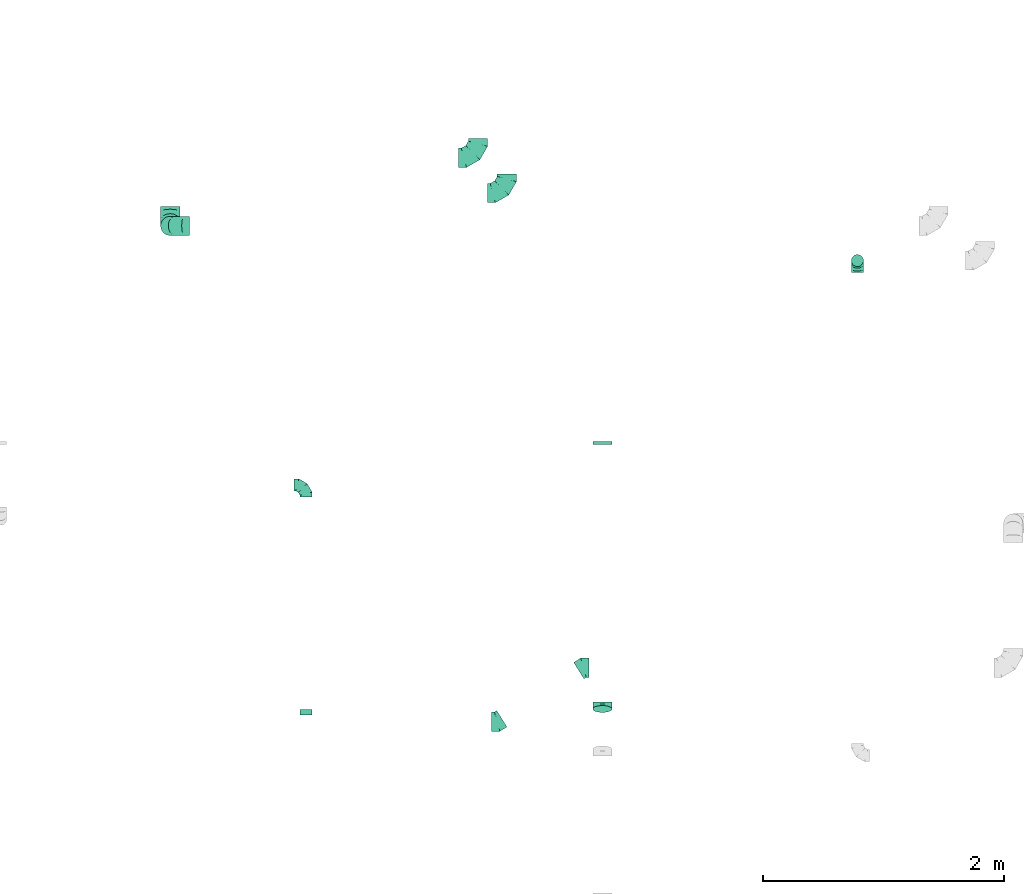
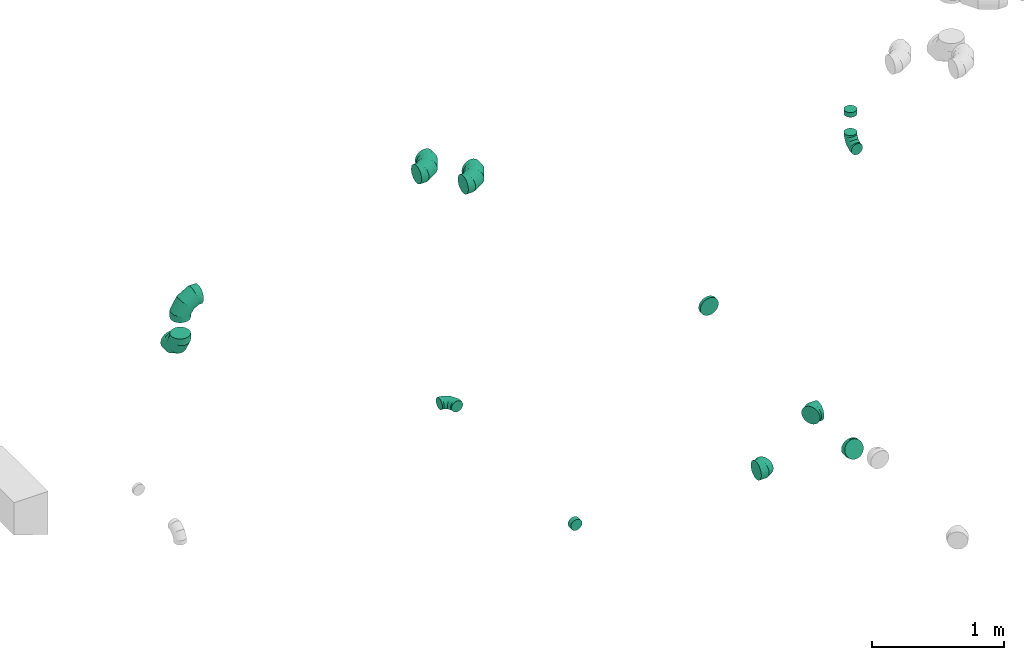
# One storey, part 5 of 32: 12 flow fittings.
"""IFC2X3 building model written with IfcOpenShell, lengths in millimetres."""

from ifc_helpers import new_model, entity, si_unit, converted_unit, derived_unit, direction, frame, origin, place, context, subcontext, project, spatial, faceted_brep, source, transform, mapped, material, type_object, type_shapes, element, save


model = new_model("IFC2X3")

# Units and contexts
model_context = context("Model", 3, precision=0.01, world=origin(), true_north=direction((6.12303176911189e-17, 1.0)))
body_context = subcontext(model_context, "Body", "Model", "MODEL_VIEW")
ifc_project = project(units=[si_unit("LENGTHUNIT", "METRE", prefix="MILLI"), si_unit("AREAUNIT", "SQUARE_METRE"), si_unit("VOLUMEUNIT", "CUBIC_METRE"), converted_unit("PLANEANGLEUNIT", "DEGREE", entity("IfcRatioMeasure", 0.0174532925199433), si_unit("PLANEANGLEUNIT", "RADIAN"), dimensions=[0, 0, 0, 0, 0, 0, 0]), si_unit("MASSUNIT", "GRAM", prefix="KILO"), derived_unit("MASSDENSITYUNIT", [(si_unit("MASSUNIT", "GRAM", prefix="KILO"), 1), (si_unit("LENGTHUNIT", "METRE"), -3)]), derived_unit("MOMENTOFINERTIAUNIT", [(si_unit("LENGTHUNIT", "METRE"), 4)]), si_unit("TIMEUNIT", "SECOND"), si_unit("FREQUENCYUNIT", "HERTZ"), si_unit("THERMODYNAMICTEMPERATUREUNIT", "DEGREE_CELSIUS"), derived_unit("THERMALTRANSMITTANCEUNIT", [(si_unit("MASSUNIT", "GRAM", prefix="KILO"), 1), (si_unit("THERMODYNAMICTEMPERATUREUNIT", "KELVIN"), -1), (si_unit("TIMEUNIT", "SECOND"), -3)]), derived_unit("VOLUMETRICFLOWRATEUNIT", [(si_unit("LENGTHUNIT", "METRE"), 3), (si_unit("TIMEUNIT", "SECOND"), -1)]), derived_unit("MASSFLOWRATEUNIT", [(si_unit("MASSUNIT", "GRAM", prefix="KILO"), 1), (si_unit("TIMEUNIT", "SECOND"), -1)]), derived_unit("ROTATIONALFREQUENCYUNIT", [(si_unit("TIMEUNIT", "SECOND"), -1)]), si_unit("ELECTRICCURRENTUNIT", "AMPERE"), si_unit("ELECTRICVOLTAGEUNIT", "VOLT"), si_unit("POWERUNIT", "WATT"), si_unit("FORCEUNIT", "NEWTON", prefix="KILO"), si_unit("ILLUMINANCEUNIT", "LUX"), si_unit("LUMINOUSFLUXUNIT", "LUMEN"), si_unit("LUMINOUSINTENSITYUNIT", "CANDELA"), derived_unit("USERDEFINED", [(si_unit("MASSUNIT", "GRAM", prefix="KILO"), -1), (si_unit("LENGTHUNIT", "METRE"), -2), (si_unit("TIMEUNIT", "SECOND"), 3), (si_unit("LUMINOUSFLUXUNIT", "LUMEN"), 1)]), derived_unit("LINEARVELOCITYUNIT", [(si_unit("LENGTHUNIT", "METRE"), 1), (si_unit("TIMEUNIT", "SECOND"), -1)]), si_unit("PRESSUREUNIT", "PASCAL"), derived_unit("USERDEFINED", [(si_unit("LENGTHUNIT", "METRE"), -2), (si_unit("MASSUNIT", "GRAM", prefix="KILO"), 1), (si_unit("TIMEUNIT", "SECOND"), -2)]), derived_unit("LINEARFORCEUNIT", [(si_unit("MASSUNIT", "GRAM", prefix="KILO"), 1), (si_unit("LENGTHUNIT", "METRE"), 1), (si_unit("TIMEUNIT", "SECOND"), -2), (si_unit("LENGTHUNIT", "METRE"), -1)]), derived_unit("PLANARFORCEUNIT", [(si_unit("MASSUNIT", "GRAM", prefix="KILO"), 1), (si_unit("LENGTHUNIT", "METRE"), 1), (si_unit("TIMEUNIT", "SECOND"), -2), (si_unit("LENGTHUNIT", "METRE"), -2)])], contexts=[model_context])

# Site, building, storey
site_placement = place(None, origin())
site = spatial("IfcSite", under=ifc_project, at=site_placement, CompositionType="ELEMENT")
building_placement = place(site_placement, origin())
building = spatial("IfcBuilding", under=site, at=building_placement, CompositionType="ELEMENT")
storey_placement = place(building_placement, frame((0.0, 0.0, 8100.0)))
storey = spatial("IfcBuildingStorey", under=building, at=storey_placement, CompositionType="ELEMENT", Elevation=8100.0)

# Flow fittings
ifc_material = material()
duct_fitting_type_1 = type_object("IfcDuctFittingType", PredefinedType="NOTDEFINED", material=ifc_material)
shared_shape_1 = source(origin(), body_context, "Body", "Brep", [
    faceted_brep([(-160.0, 0.0, -80.0), (-160.0, -20.71, -77.27), (-160.0, -40.0, -69.28), (-160.0, -56.57, -56.57), (-160.0, -69.28, -40.0), (-160.0, -77.27, -20.71), (-160.0, -80.0, 0.0), (-160.0, -77.27, 20.71), (-160.0, -69.28, 40.0), (-160.0, -56.57, 56.57), (-160.0, -40.0, 69.28), (-160.0, -20.71, 77.27), (-160.0, 0.0, 80.0), (-160.0, 20.71, 77.27), (-160.0, 40.0, 69.28), (-160.0, 56.57, 56.57), (-160.0, 69.28, 40.0), (-160.0, 77.27, 20.71), (-160.0, 80.0, 0.0), (-160.0, 77.27, -20.71), (-160.0, 69.28, -40.0), (-160.0, 56.57, -56.57), (-160.0, 40.0, -69.28), (-160.0, 20.71, -77.27), (-122.68, 20.71, 77.27), (-127.85, 40.0, 69.28), (-117.13, 0.0, 80.0), (-132.29, 56.57, 56.57), (-137.83, 77.27, 20.71), (-138.56, 80.0, 0.0), (-135.69, 69.28, 40.0), (-135.69, 69.28, -40.0), (-132.29, 56.57, -56.57), (-137.83, 77.27, -20.71), (-122.68, 20.71, -77.27), (-117.13, 0.0, -80.0), (-127.85, 40.0, -69.28), (-111.58, -20.71, -77.27), (-106.41, -40.0, -69.28), (-101.97, -56.57, -56.57), (-98.56, -69.28, -40.0), (-96.42, -77.27, -20.71), (-95.69, -80.0, 0.0), (-96.42, -77.27, 20.71), (-98.56, -69.28, 40.0), (-101.97, -56.57, 56.57), (-106.41, -40.0, 69.28), (-111.58, -20.71, 77.27), (-58.03, 58.03, 77.27), (-72.15, 72.15, 69.28), (-42.87, 42.87, 80.0), (-84.28, 84.28, 56.57), (-93.59, 93.59, 40.0), (-99.44, 99.44, 20.71), (-101.44, 101.44, 0.0), (-99.44, 99.44, -20.71), (-93.59, 93.59, -40.0), (-84.28, 84.28, -56.57), (-58.03, 58.03, -77.27), (-42.87, 42.87, -80.0), (-72.15, 72.15, -69.28), (-27.71, 27.71, -77.27), (-13.59, 13.59, -69.28), (-1.46, 1.46, -56.57), (7.85, -7.85, -40.0), (13.7, -13.7, -20.71), (15.69, -15.69, 0.0), (13.7, -13.7, 20.71), (7.85, -7.85, 40.0), (-1.46, 1.46, 56.57), (-13.59, 13.59, 69.28), (-27.71, 27.71, 77.27), (-20.71, 122.68, 77.27), (-40.0, 127.85, 69.28), (0.0, 117.13, 80.0), (-56.57, 132.29, 56.57), (-69.28, 135.69, 40.0), (-77.27, 137.83, 20.71), (-80.0, 138.56, 0.0), (-77.27, 137.83, -20.71), (-69.28, 135.69, -40.0), (-56.57, 132.29, -56.57), (-20.71, 122.68, -77.27), (0.0, 117.13, -80.0), (-40.0, 127.85, -69.28), (20.71, 111.58, -77.27), (40.0, 106.41, -69.28), (56.57, 101.97, -56.57), (69.28, 98.56, -40.0), (77.27, 96.42, -20.71), (80.0, 95.69, 0.0), (77.27, 96.42, 20.71), (69.28, 98.56, 40.0), (56.57, 101.97, 56.57), (40.0, 106.41, 69.28), (20.71, 111.58, 77.27), (-20.71, 160.0, -77.27), (-40.0, 160.0, -69.28), (-56.57, 160.0, -56.57), (-69.28, 160.0, -40.0), (-77.27, 160.0, -20.71), (-80.0, 160.0, 0.0), (-77.27, 160.0, 20.71), (-69.28, 160.0, 40.0), (-56.57, 160.0, 56.57), (-40.0, 160.0, 69.28), (-20.71, 160.0, 77.27), (0.0, 160.0, 80.0), (20.71, 160.0, 77.27), (40.0, 160.0, 69.28), (56.57, 160.0, 56.57), (69.28, 160.0, 40.0), (77.27, 160.0, 20.71), (80.0, 160.0, 0.0), (77.27, 160.0, -20.71), (69.28, 160.0, -40.0), (56.57, 160.0, -56.57), (40.0, 160.0, -69.28), (20.71, 160.0, -77.27), (0.0, 160.0, -80.0)], [[[0, 1, 2, 3, 4, 5, 6, 7, 8, 9, 10, 11, 12, 13, 14, 15, 16, 17, 18, 19, 20, 21, 22, 23]], [[24, 25, 14, 13]], [[26, 24, 13, 12]], [[14, 25, 27, 15]], [[28, 29, 18, 17]], [[30, 28, 17, 16]], [[15, 27, 30, 16]], [[20, 31, 32, 21]], [[33, 31, 20, 19]], [[18, 29, 33, 19]], [[34, 35, 0, 23]], [[36, 34, 23, 22]], [[32, 36, 22, 21]], [[1, 0, 35, 37]], [[2, 1, 37, 38]], [[3, 2, 38, 39]], [[5, 4, 40, 41]], [[6, 5, 41, 42]], [[39, 40, 4, 3]], [[6, 42, 43, 7]], [[7, 43, 44, 8]], [[8, 44, 45, 9]], [[9, 45, 46, 10]], [[10, 46, 47, 11]], [[26, 12, 11, 47]], [[48, 49, 25, 24]], [[50, 48, 24, 26]], [[27, 25, 49, 51]], [[52, 53, 28, 30]], [[51, 52, 30, 27]], [[29, 28, 53, 54]], [[55, 56, 31, 33]], [[54, 55, 33, 29]], [[32, 31, 56, 57]], [[58, 59, 35, 34]], [[60, 58, 34, 36]], [[57, 60, 36, 32]], [[37, 35, 59, 61]], [[38, 37, 61, 62]], [[39, 38, 62, 63]], [[41, 40, 64, 65]], [[42, 41, 65, 66]], [[63, 64, 40, 39]], [[43, 42, 66, 67]], [[44, 43, 67, 68]], [[68, 69, 45, 44]], [[46, 45, 69, 70]], [[47, 46, 70, 71]], [[26, 47, 71, 50]], [[72, 73, 49, 48]], [[74, 72, 48, 50]], [[51, 49, 73, 75]], [[76, 77, 53, 52]], [[75, 76, 52, 51]], [[54, 53, 77, 78]], [[79, 80, 56, 55]], [[78, 79, 55, 54]], [[57, 56, 80, 81]], [[82, 83, 59, 58]], [[84, 82, 58, 60]], [[81, 84, 60, 57]], [[61, 59, 83, 85]], [[62, 61, 85, 86]], [[63, 62, 86, 87]], [[65, 64, 88, 89]], [[66, 65, 89, 90]], [[87, 88, 64, 63]], [[67, 66, 90, 91]], [[68, 67, 91, 92]], [[92, 93, 69, 68]], [[70, 69, 93, 94]], [[71, 70, 94, 95]], [[50, 71, 95, 74]], [[96, 97, 98, 99, 100, 101, 102, 103, 104, 105, 106, 107, 108, 109, 110, 111, 112, 113, 114, 115, 116, 117, 118, 119]], [[72, 74, 107, 106]], [[73, 72, 106, 105]], [[75, 73, 105, 104]], [[77, 76, 103, 102]], [[78, 77, 102, 101]], [[75, 104, 103, 76]], [[78, 101, 100, 79]], [[79, 100, 99, 80]], [[80, 99, 98, 81]], [[84, 97, 96, 82]], [[82, 96, 119, 83]], [[84, 81, 98, 97]], [[118, 117, 86, 85]], [[119, 118, 85, 83]], [[116, 87, 86, 117]], [[88, 115, 114, 89]], [[89, 114, 113, 90]], [[115, 88, 87, 116]], [[112, 111, 92, 91]], [[113, 112, 91, 90]], [[111, 110, 93, 92]], [[95, 94, 109, 108]], [[74, 95, 108, 107]], [[110, 109, 94, 93]]]),
])
type_shapes(duct_fitting_type_1, [shared_shape_1])
for number, where in (
    (1, (13323.56, 12986.64, 3350.0)),
    (2, (13083.56, 13280.27, 3350.0)),
):
    element("IfcFlowFitting", number, at=place(storey_placement, frame(where)), inside=storey, type_object=duct_fitting_type_1, material=ifc_material, context=body_context, shape_type="MappedRepresentation", body=[
        mapped(shared_shape_1, transform((0.0, 0.0, 0.0), scale=1.0)),
    ])
for number, where, z_axis, x_axis in (
    (3, (10524.9, 12714.35, 2900.0), (-1.0, 0.0, 0.0), (0.0, -1.0, 0.0)),
    (4, (10524.9, 12714.35, 3370.0), (0.0, -1.0, 0.0), (-1.0, 0.0, 0.0)),
):
    element("IfcFlowFitting", number, at=place(storey_placement, frame(where, z_axis=z_axis, x_axis=x_axis)), inside=storey, type_object=duct_fitting_type_1, material=ifc_material, context=body_context, shape_type="MappedRepresentation", body=[
        mapped(shared_shape_1, transform((0.0, 0.0, 0.0), scale=1.0)),
    ])
duct_fitting_type_2 = type_object("IfcDuctFittingType", PredefinedType="NOTDEFINED", material=ifc_material)
shared_shape_2 = source(origin(), body_context, "Body", "Brep", [
    faceted_brep([(-100.0, 0.0, -50.0), (-100.0, -12.94, -48.3), (-100.0, -25.0, -43.3), (-100.0, -35.36, -35.36), (-100.0, -43.3, -25.0), (-100.0, -48.3, -12.94), (-100.0, -50.0, 0.0), (-100.0, -48.3, 12.94), (-100.0, -43.3, 25.0), (-100.0, -35.36, 35.36), (-100.0, -25.0, 43.3), (-100.0, -12.94, 48.3), (-100.0, 0.0, 50.0), (-100.0, 12.94, 48.3), (-100.0, 25.0, 43.3), (-100.0, 35.36, 35.36), (-100.0, 43.3, 25.0), (-100.0, 48.3, 12.94), (-100.0, 50.0, 0.0), (-100.0, 48.3, -12.94), (-100.0, 43.3, -25.0), (-100.0, 35.36, -35.36), (-100.0, 25.0, -43.3), (-100.0, 12.94, -48.3), (-76.67, 12.94, 48.3), (-79.9, 25.0, 43.3), (-73.21, 0.0, 50.0), (-82.68, 35.36, 35.36), (-86.15, 48.3, 12.94), (-86.6, 50.0, 0.0), (-84.81, 43.3, 25.0), (-84.81, 43.3, -25.0), (-82.68, 35.36, -35.36), (-86.15, 48.3, -12.94), (-76.67, 12.94, -48.3), (-73.21, 0.0, -50.0), (-79.9, 25.0, -43.3), (-69.74, -12.94, -48.3), (-66.51, -25.0, -43.3), (-63.73, -35.36, -35.36), (-61.6, -43.3, -25.0), (-60.26, -48.3, -12.94), (-59.81, -50.0, 0.0), (-60.26, -48.3, 12.94), (-61.6, -43.3, 25.0), (-63.73, -35.36, 35.36), (-66.51, -25.0, 43.3), (-69.74, -12.94, 48.3), (-36.27, 36.27, 48.3), (-45.1, 45.1, 43.3), (-26.79, 26.79, 50.0), (-52.68, 52.68, 35.36), (-58.49, 58.49, 25.0), (-62.15, 62.15, 12.94), (-63.4, 63.4, 0.0), (-62.15, 62.15, -12.94), (-58.49, 58.49, -25.0), (-52.68, 52.68, -35.36), (-36.27, 36.27, -48.3), (-26.79, 26.79, -50.0), (-45.1, 45.1, -43.3), (-17.32, 17.32, -48.3), (-8.49, 8.49, -43.3), (-0.91, 0.91, -35.36), (4.9, -4.9, -25.0), (8.56, -8.56, -12.94), (9.81, -9.81, 0.0), (8.56, -8.56, 12.94), (4.9, -4.9, 25.0), (-0.91, 0.91, 35.36), (-8.49, 8.49, 43.3), (-17.32, 17.32, 48.3), (-12.94, 76.67, 48.3), (-25.0, 79.9, 43.3), (0.0, 73.21, 50.0), (-35.36, 82.68, 35.36), (-43.3, 84.81, 25.0), (-48.3, 86.15, 12.94), (-50.0, 86.6, 0.0), (-48.3, 86.15, -12.94), (-43.3, 84.81, -25.0), (-35.36, 82.68, -35.36), (-12.94, 76.67, -48.3), (0.0, 73.21, -50.0), (-25.0, 79.9, -43.3), (12.94, 69.74, -48.3), (25.0, 66.51, -43.3), (35.36, 63.73, -35.36), (43.3, 61.6, -25.0), (48.3, 60.26, -12.94), (50.0, 59.81, 0.0), (48.3, 60.26, 12.94), (43.3, 61.6, 25.0), (35.36, 63.73, 35.36), (25.0, 66.51, 43.3), (12.94, 69.74, 48.3), (-12.94, 100.0, -48.3), (-25.0, 100.0, -43.3), (-35.36, 100.0, -35.36), (-43.3, 100.0, -25.0), (-48.3, 100.0, -12.94), (-50.0, 100.0, 0.0), (-48.3, 100.0, 12.94), (-43.3, 100.0, 25.0), (-35.36, 100.0, 35.36), (-25.0, 100.0, 43.3), (-12.94, 100.0, 48.3), (0.0, 100.0, 50.0), (12.94, 100.0, 48.3), (25.0, 100.0, 43.3), (35.36, 100.0, 35.36), (43.3, 100.0, 25.0), (48.3, 100.0, 12.94), (50.0, 100.0, 0.0), (48.3, 100.0, -12.94), (43.3, 100.0, -25.0), (35.36, 100.0, -35.36), (25.0, 100.0, -43.3), (12.94, 100.0, -48.3), (0.0, 100.0, -50.0)], [[[0, 1, 2, 3, 4, 5, 6, 7, 8, 9, 10, 11, 12, 13, 14, 15, 16, 17, 18, 19, 20, 21, 22, 23]], [[24, 25, 14, 13]], [[26, 24, 13, 12]], [[14, 25, 27, 15]], [[28, 29, 18, 17]], [[30, 28, 17, 16]], [[15, 27, 30, 16]], [[20, 31, 32, 21]], [[33, 31, 20, 19]], [[18, 29, 33, 19]], [[34, 35, 0, 23]], [[36, 34, 23, 22]], [[32, 36, 22, 21]], [[2, 1, 37, 38]], [[3, 2, 38, 39]], [[0, 35, 37, 1]], [[5, 4, 40, 41]], [[6, 5, 41, 42]], [[3, 39, 40, 4]], [[6, 42, 43, 7]], [[7, 43, 44, 8]], [[8, 44, 45, 9]], [[10, 46, 47, 11]], [[11, 47, 26, 12]], [[10, 9, 45, 46]], [[48, 49, 25, 24]], [[50, 48, 24, 26]], [[27, 25, 49, 51]], [[52, 53, 28, 30]], [[51, 52, 30, 27]], [[29, 28, 53, 54]], [[55, 56, 31, 33]], [[54, 55, 33, 29]], [[57, 32, 31, 56]], [[58, 59, 35, 34]], [[60, 58, 34, 36]], [[57, 60, 36, 32]], [[37, 35, 59, 61]], [[38, 37, 61, 62]], [[39, 38, 62, 63]], [[41, 40, 64, 65]], [[42, 41, 65, 66]], [[63, 64, 40, 39]], [[43, 42, 66, 67]], [[44, 43, 67, 68]], [[68, 69, 45, 44]], [[46, 45, 69, 70]], [[47, 46, 70, 71]], [[26, 47, 71, 50]], [[72, 73, 49, 48]], [[74, 72, 48, 50]], [[51, 49, 73, 75]], [[76, 77, 53, 52]], [[75, 76, 52, 51]], [[54, 53, 77, 78]], [[79, 80, 56, 55]], [[78, 79, 55, 54]], [[81, 57, 56, 80]], [[82, 83, 59, 58]], [[84, 82, 58, 60]], [[81, 84, 60, 57]], [[61, 59, 83, 85]], [[62, 61, 85, 86]], [[63, 62, 86, 87]], [[65, 64, 88, 89]], [[66, 65, 89, 90]], [[87, 88, 64, 63]], [[67, 66, 90, 91]], [[68, 67, 91, 92]], [[92, 93, 69, 68]], [[70, 69, 93, 94]], [[71, 70, 94, 95]], [[50, 71, 95, 74]], [[96, 97, 98, 99, 100, 101, 102, 103, 104, 105, 106, 107, 108, 109, 110, 111, 112, 113, 114, 115, 116, 117, 118, 119]], [[72, 74, 107, 106]], [[73, 72, 106, 105]], [[75, 73, 105, 104]], [[77, 76, 103, 102]], [[78, 77, 102, 101]], [[75, 104, 103, 76]], [[78, 101, 100, 79]], [[79, 100, 99, 80]], [[80, 99, 98, 81]], [[96, 119, 83, 82]], [[97, 96, 82, 84]], [[84, 81, 98, 97]], [[83, 119, 118, 85]], [[85, 118, 117, 86]], [[86, 117, 116, 87]], [[88, 115, 114, 89]], [[89, 114, 113, 90]], [[87, 116, 115, 88]], [[91, 90, 113, 112]], [[92, 91, 112, 111]], [[93, 92, 111, 110]], [[95, 94, 109, 108]], [[74, 95, 108, 107]], [[110, 109, 94, 93]]]),
])
type_shapes(duct_fitting_type_2, [shared_shape_2])
for number, where, z_axis, x_axis in (
    (5, (11654.01, 10561.51, 3350.0), (0.0, 0.0, 1.0), (0.0, 1.0, 0.0)),
    (6, (16237.59, 12425.69, 3000.0), (-1.0, 0.0, 0.0), (0.0, 0.0, -1.0)),
):
    element("IfcFlowFitting", number, at=place(storey_placement, frame(where, z_axis=z_axis, x_axis=x_axis)), inside=storey, type_object=duct_fitting_type_2, material=ifc_material, context=body_context, shape_type="MappedRepresentation", body=[
        mapped(shared_shape_2, transform((0.0, 0.0, 0.0), scale=1.0)),
    ])
duct_fitting_type_3 = type_object("IfcDuctFittingType", PredefinedType="NOTDEFINED", material=ifc_material)
shared_shape_3 = source(origin(), body_context, "Body", "Brep", [
    faceted_brep([(20.0, 12.94, -48.3), (20.0, 25.0, -43.3), (20.0, 35.36, -35.36), (20.0, 43.3, -25.0), (20.0, 48.3, -12.94), (20.0, 50.0, 0.0), (20.0, 48.3, 12.94), (20.0, 43.3, 25.0), (20.0, 35.36, 35.36), (20.0, 25.0, 43.3), (20.0, 12.94, 48.3), (20.0, 0.0, 50.0), (20.0, -12.94, 48.3), (20.0, -25.0, 43.3), (20.0, -35.36, 35.36), (20.0, -43.3, 25.0), (20.0, -48.3, 12.94), (20.0, -50.0, 0.0), (20.0, -48.3, -12.94), (20.0, -43.3, -25.0), (20.0, -35.36, -35.36), (20.0, -25.0, -43.3), (20.0, -12.94, -48.3), (20.0, 0.0, -50.0), (0.0, 0.0, 50.0), (0.0, 12.94, 48.3), (-23.65, 12.94, 48.3), (-23.65, 0.0, 50.0), (0.0, 25.0, 43.3), (-23.65, 25.0, 43.3), (0.0, 35.36, 35.36), (-23.65, 35.36, 35.36), (0.0, 43.3, 25.0), (0.0, 48.3, 12.94), (-23.65, 48.3, 12.94), (-23.65, 43.3, 25.0), (0.0, 50.0, 0.0), (-23.65, 50.0, 0.0), (0.0, 48.3, -12.94), (-23.65, 48.3, -12.94), (0.0, 43.3, -25.0), (-23.65, 43.3, -25.0), (0.0, 35.36, -35.36), (-23.65, 35.36, -35.36), (0.0, 25.0, -43.3), (0.0, 12.94, -48.3), (-23.65, 12.94, -48.3), (-23.65, 25.0, -43.3), (0.0, 0.0, -50.0), (-23.65, 0.0, -50.0), (0.0, -12.94, -48.3), (-23.65, -12.94, -48.3), (0.0, -25.0, -43.3), (-23.65, -25.0, -43.3), (0.0, -35.36, -35.36), (-23.65, -35.36, -35.36), (0.0, -43.3, -25.0), (0.0, -48.3, -12.94), (-23.65, -48.3, -12.94), (-23.65, -43.3, -25.0), (0.0, -50.0, 0.0), (-23.65, -50.0, 0.0), (0.0, -48.3, 12.94), (-23.65, -48.3, 12.94), (0.0, -43.3, 25.0), (-23.65, -43.3, 25.0), (0.0, -35.36, 35.36), (-23.65, -35.36, 35.36), (0.0, -25.0, 43.3), (0.0, -12.94, 48.3), (-23.65, -12.94, 48.3), (-23.65, -25.0, 43.3)], [[[0, 1, 2, 3, 4, 5, 6, 7, 8, 9, 10, 11, 12, 13, 14, 15, 16, 17, 18, 19, 20, 21, 22, 23]], [[24, 11, 10, 25, 26, 27]], [[25, 10, 9, 28, 29, 26]], [[28, 9, 8, 30, 31, 29]], [[32, 7, 6, 33, 34, 35]], [[33, 6, 5, 36, 37, 34]], [[30, 8, 7, 32, 35, 31]], [[36, 5, 4, 38, 39, 37]], [[38, 4, 3, 40, 41, 39]], [[40, 3, 2, 42, 43, 41]], [[44, 1, 0, 45, 46, 47]], [[45, 0, 23, 48, 49, 46]], [[42, 2, 1, 44, 47, 43]], [[48, 23, 22, 50, 51, 49]], [[50, 22, 21, 52, 53, 51]], [[52, 21, 20, 54, 55, 53]], [[56, 19, 18, 57, 58, 59]], [[57, 18, 17, 60, 61, 58]], [[54, 20, 19, 56, 59, 55]], [[60, 17, 16, 62, 63, 61]], [[62, 16, 15, 64, 65, 63]], [[64, 15, 14, 66, 67, 65]], [[68, 13, 12, 69, 70, 71]], [[69, 12, 11, 24, 27, 70]], [[66, 14, 13, 68, 71, 67]], [[49, 51, 53, 55, 59, 58, 61, 63, 65, 67, 71, 70, 27, 26, 29, 31, 35, 34, 37, 39, 41, 43, 47, 46]]]),
])
type_shapes(duct_fitting_type_3, [shared_shape_3])
flow_fitting_1_placement = place(storey_placement, frame((11654.01, 8672.96, 3350.0), z_axis=(0.0, 0.0, -1.0), x_axis=(0.0, 1.0, 0.0)))
element("IfcFlowFitting", 7, at=flow_fitting_1_placement, inside=storey, type_object=duct_fitting_type_3, material=ifc_material, context=body_context, shape_type="MappedRepresentation", body=[
    mapped(shared_shape_3, transform((0.0, 0.0, 0.0), scale=1.0)),
])
duct_fitting_type_4 = type_object("IfcDuctFittingType", PredefinedType="NOTDEFINED", material=ifc_material)
shared_shape_4 = source(origin(), body_context, "Body", "Brep", [
    faceted_brep([(20.0, 0.0, -50.0), (20.0, 12.94, -48.3), (20.0, 25.0, -43.3), (20.0, 35.36, -35.36), (20.0, 43.3, -25.0), (20.0, 48.3, -12.94), (20.0, 50.0, 0.0), (20.0, 48.3, 12.94), (20.0, 43.3, 25.0), (20.0, 35.36, 35.36), (20.0, 25.0, 43.3), (20.0, 12.94, 48.3), (20.0, 0.0, 50.0), (20.0, -12.94, 48.3), (20.0, -25.0, 43.3), (20.0, -35.36, 35.36), (20.0, -43.3, 25.0), (20.0, -48.3, 12.94), (20.0, -50.0, 0.0), (20.0, -48.3, -12.94), (20.0, -43.3, -25.0), (20.0, -35.36, -35.36), (20.0, -25.0, -43.3), (20.0, -12.94, -48.3), (0.0, 0.0, 50.0), (-23.65, 0.0, 50.0), (-23.65, -12.94, 48.3), (0.0, -12.94, 48.3), (-23.65, -25.0, 43.3), (0.0, -25.0, 43.3), (0.0, -35.36, 35.36), (-23.65, -35.36, 35.36), (0.0, -43.3, 25.0), (-23.65, -43.3, 25.0), (-23.65, -48.3, 12.94), (0.0, -48.3, 12.94), (-23.65, -50.0, 0.0), (0.0, -50.0, 0.0), (-23.65, -48.3, -12.94), (0.0, -48.3, -12.94), (-23.65, -43.3, -25.0), (0.0, -43.3, -25.0), (0.0, -35.36, -35.36), (-23.65, -35.36, -35.36), (0.0, -25.0, -43.3), (-23.65, -25.0, -43.3), (-23.65, -12.94, -48.3), (0.0, -12.94, -48.3), (-23.65, 0.0, -50.0), (0.0, 0.0, -50.0), (-23.65, 12.94, -48.3), (0.0, 12.94, -48.3), (-23.65, 25.0, -43.3), (0.0, 25.0, -43.3), (0.0, 35.36, -35.36), (-23.65, 35.36, -35.36), (0.0, 43.3, -25.0), (-23.65, 43.3, -25.0), (-23.65, 48.3, -12.94), (0.0, 48.3, -12.94), (-23.65, 50.0, 0.0), (0.0, 50.0, 0.0), (-23.65, 48.3, 12.94), (0.0, 48.3, 12.94), (-23.65, 43.3, 25.0), (0.0, 43.3, 25.0), (0.0, 35.36, 35.36), (-23.65, 35.36, 35.36), (0.0, 25.0, 43.3), (-23.65, 25.0, 43.3), (-23.65, 12.94, 48.3), (0.0, 12.94, 48.3)], [[[0, 1, 2, 3, 4, 5, 6, 7, 8, 9, 10, 11, 12, 13, 14, 15, 16, 17, 18, 19, 20, 21, 22, 23]], [[13, 12, 24, 25, 26, 27]], [[14, 13, 27, 26, 28, 29]], [[30, 15, 14, 29, 28, 31]], [[17, 16, 32, 33, 34, 35]], [[18, 17, 35, 34, 36, 37]], [[32, 16, 15, 30, 31, 33]], [[19, 18, 37, 36, 38, 39]], [[20, 19, 39, 38, 40, 41]], [[42, 21, 20, 41, 40, 43]], [[23, 22, 44, 45, 46, 47]], [[0, 23, 47, 46, 48, 49]], [[44, 22, 21, 42, 43, 45]], [[1, 0, 49, 48, 50, 51]], [[2, 1, 51, 50, 52, 53]], [[54, 3, 2, 53, 52, 55]], [[5, 4, 56, 57, 58, 59]], [[6, 5, 59, 58, 60, 61]], [[56, 4, 3, 54, 55, 57]], [[7, 6, 61, 60, 62, 63]], [[8, 7, 63, 62, 64, 65]], [[66, 9, 8, 65, 64, 67]], [[11, 10, 68, 69, 70, 71]], [[12, 11, 71, 70, 25, 24]], [[68, 10, 9, 66, 67, 69]], [[46, 45, 43, 40, 38, 36, 34, 33, 31, 28, 26, 25, 70, 69, 67, 64, 62, 60, 58, 57, 55, 52, 50, 48]]]),
])
type_shapes(duct_fitting_type_4, [shared_shape_4])
flow_fitting_2_placement = place(storey_placement, frame((16237.59, 12425.69, 3290.0), z_axis=(0.0, -1.0, 0.0), x_axis=(0.0, 0.0, -1.0)))
element("IfcFlowFitting", 8, at=flow_fitting_2_placement, inside=storey, type_object=duct_fitting_type_4, material=ifc_material, context=body_context, shape_type="MappedRepresentation", body=[
    mapped(shared_shape_4, transform((0.0, 0.0, 0.0), scale=1.0)),
])
duct_fitting_type_5 = type_object("IfcDuctFittingType", PredefinedType="NOTDEFINED", material=ifc_material)
shared_shape_5 = source(origin(), body_context, "Body", "Brep", [
    faceted_brep([(20.0, 20.71, -77.27), (20.0, 40.0, -69.28), (20.0, 56.57, -56.57), (20.0, 69.28, -40.0), (20.0, 77.27, -20.71), (20.0, 80.0, 0.0), (20.0, 77.27, 20.71), (20.0, 69.28, 40.0), (20.0, 56.57, 56.57), (20.0, 40.0, 69.28), (20.0, 20.71, 77.27), (20.0, 0.0, 80.0), (20.0, -20.71, 77.27), (20.0, -40.0, 69.28), (20.0, -56.57, 56.57), (20.0, -69.28, 40.0), (20.0, -77.27, 20.71), (20.0, -80.0, 0.0), (20.0, -77.27, -20.71), (20.0, -69.28, -40.0), (20.0, -56.57, -56.57), (20.0, -40.0, -69.28), (20.0, -20.71, -77.27), (20.0, 0.0, -80.0), (0.0, 0.0, 80.0), (0.0, 20.71, 77.27), (-6.1, 20.71, 77.27), (-6.1, 0.0, 80.0), (0.0, 40.0, 69.28), (-6.1, 40.0, 69.28), (0.0, 56.57, 56.57), (-6.1, 56.57, 56.57), (0.0, 69.28, 40.0), (0.0, 77.27, 20.71), (-6.1, 77.27, 20.71), (-6.1, 69.28, 40.0), (0.0, 80.0, 0.0), (-6.1, 80.0, 0.0), (0.0, 77.27, -20.71), (-6.1, 77.27, -20.71), (0.0, 69.28, -40.0), (-6.1, 69.28, -40.0), (0.0, 56.57, -56.57), (-6.1, 56.57, -56.57), (0.0, 40.0, -69.28), (0.0, 20.71, -77.27), (-6.1, 20.71, -77.27), (-6.1, 40.0, -69.28), (0.0, 0.0, -80.0), (-6.1, 0.0, -80.0), (0.0, -20.71, -77.27), (-6.1, -20.71, -77.27), (0.0, -40.0, -69.28), (-6.1, -40.0, -69.28), (0.0, -56.57, -56.57), (-6.1, -56.57, -56.57), (0.0, -69.28, -40.0), (0.0, -77.27, -20.71), (-6.1, -77.27, -20.71), (-6.1, -69.28, -40.0), (0.0, -80.0, 0.0), (-6.1, -80.0, 0.0), (0.0, -77.27, 20.71), (-6.1, -77.27, 20.71), (0.0, -69.28, 40.0), (-6.1, -69.28, 40.0), (0.0, -56.57, 56.57), (-6.1, -56.57, 56.57), (0.0, -40.0, 69.28), (0.0, -20.71, 77.27), (-6.1, -20.71, 77.27), (-6.1, -40.0, 69.28)], [[[0, 1, 2, 3, 4, 5, 6, 7, 8, 9, 10, 11, 12, 13, 14, 15, 16, 17, 18, 19, 20, 21, 22, 23]], [[24, 11, 10, 25, 26, 27]], [[25, 10, 9, 28, 29, 26]], [[28, 9, 8, 30, 31, 29]], [[32, 7, 6, 33, 34, 35]], [[33, 6, 5, 36, 37, 34]], [[30, 8, 7, 32, 35, 31]], [[36, 5, 4, 38, 39, 37]], [[38, 4, 3, 40, 41, 39]], [[40, 3, 2, 42, 43, 41]], [[44, 1, 0, 45, 46, 47]], [[45, 0, 23, 48, 49, 46]], [[42, 2, 1, 44, 47, 43]], [[48, 23, 22, 50, 51, 49]], [[50, 22, 21, 52, 53, 51]], [[52, 21, 20, 54, 55, 53]], [[56, 19, 18, 57, 58, 59]], [[57, 18, 17, 60, 61, 58]], [[54, 20, 19, 56, 59, 55]], [[60, 17, 16, 62, 63, 61]], [[62, 16, 15, 64, 65, 63]], [[64, 15, 14, 66, 67, 65]], [[68, 13, 12, 69, 70, 71]], [[69, 12, 11, 24, 27, 70]], [[66, 14, 13, 68, 71, 67]], [[49, 51, 53, 55, 59, 58, 61, 63, 65, 67, 71, 70, 27, 26, 29, 31, 35, 34, 37, 39, 41, 43, 47, 46]]]),
])
type_shapes(duct_fitting_type_5, [shared_shape_5])
flow_fitting_3_placement = place(storey_placement, frame((14117.94, 10917.22, 3150.0), z_axis=(0.0, 0.0, -1.0), x_axis=(0.0, -1.0, 0.0)))
element("IfcFlowFitting", 9, at=flow_fitting_3_placement, inside=storey, type_object=duct_fitting_type_5, material=ifc_material, context=body_context, shape_type="MappedRepresentation", body=[
    mapped(shared_shape_5, transform((0.0, 0.0, 0.0), scale=1.0)),
])
duct_fitting_type_6 = type_object("IfcDuctFittingType", PredefinedType="NOTDEFINED", material=ifc_material)
shared_shape_6 = source(origin(), body_context, "Body", "Brep", [
    faceted_brep([(-45.88, 0.0, -80.0), (-45.88, -20.71, -77.27), (-45.88, -40.0, -69.28), (-45.88, -56.57, -56.57), (-45.88, -69.28, -40.0), (-45.88, -77.27, -20.71), (-45.88, -80.0, 0.0), (-45.88, -77.27, 20.71), (-45.88, -69.28, 40.0), (-45.88, -56.57, 56.57), (-45.88, -40.0, 69.28), (-45.88, -20.71, 77.27), (-45.88, 0.0, 80.0), (-45.88, 20.71, 77.27), (-45.88, 40.0, 69.28), (-45.88, 56.57, 56.57), (-45.88, 69.28, 40.0), (-45.88, 77.27, 20.71), (-45.88, 80.0, 0.0), (-45.88, 77.27, -20.71), (-45.88, 69.28, -40.0), (-45.88, 56.57, -56.57), (-45.88, 40.0, -69.28), (-45.88, 20.71, -77.27), (-5.94, 20.71, 77.27), (-11.47, 40.0, 69.28), (0.0, 0.0, 80.0), (-16.22, 56.57, 56.57), (-22.16, 77.27, 20.71), (-22.94, 80.0, 0.0), (-19.87, 69.28, 40.0), (-19.87, 69.28, -40.0), (-16.22, 56.57, -56.57), (-22.16, 77.27, -20.71), (-5.94, 20.71, -77.27), (0.0, 0.0, -80.0), (-11.47, 40.0, -69.28), (5.94, -20.71, -77.27), (11.47, -40.0, -69.28), (16.22, -56.57, -56.57), (19.87, -69.28, -40.0), (22.16, -77.27, -20.71), (22.94, -80.0, 0.0), (22.16, -77.27, 20.71), (19.87, -69.28, 40.0), (16.22, -56.57, 56.57), (11.47, -40.0, 69.28), (5.94, -20.71, 77.27), (38.91, 24.31, 80.0), (27.94, 41.87, 77.27), (17.71, 58.23, 69.28), (8.93, 72.29, 56.57), (2.19, 83.07, 40.0), (-2.04, 89.84, 20.71), (-3.49, 92.16, 0.0), (-2.04, 89.84, -20.71), (2.19, 83.07, -40.0), (8.93, 72.29, -56.57), (17.71, 58.23, -69.28), (27.94, 41.87, -77.27), (38.91, 24.31, -80.0), (49.88, 6.75, -77.27), (60.1, -9.61, -69.28), (68.88, -23.66, -56.57), (75.62, -34.44, -40.0), (79.86, -41.22, -20.71), (81.3, -43.53, 0.0), (79.86, -41.22, 20.71), (75.62, -34.44, 40.0), (68.88, -23.66, 56.57), (60.1, -9.61, 69.28), (49.88, 6.75, 77.27)], [[[0, 1, 2, 3, 4, 5, 6, 7, 8, 9, 10, 11, 12, 13, 14, 15, 16, 17, 18, 19, 20, 21, 22, 23]], [[24, 25, 14, 13]], [[26, 24, 13, 12]], [[14, 25, 27, 15]], [[28, 29, 18, 17]], [[30, 28, 17, 16]], [[15, 27, 30, 16]], [[20, 31, 32, 21]], [[33, 31, 20, 19]], [[18, 29, 33, 19]], [[34, 35, 0, 23]], [[36, 34, 23, 22]], [[32, 36, 22, 21]], [[1, 0, 35, 37]], [[2, 1, 37, 38]], [[38, 39, 3, 2]], [[5, 4, 40, 41]], [[6, 5, 41, 42]], [[39, 40, 4, 3]], [[6, 42, 43, 7]], [[7, 43, 44, 8]], [[8, 44, 45, 9]], [[9, 45, 46, 10]], [[10, 46, 47, 11]], [[26, 12, 11, 47]], [[24, 26, 48, 49]], [[25, 24, 49, 50]], [[27, 25, 50, 51]], [[28, 30, 52, 53]], [[29, 28, 53, 54]], [[27, 51, 52, 30]], [[29, 54, 55, 33]], [[33, 55, 56, 31]], [[31, 56, 57, 32]], [[36, 58, 59, 34]], [[34, 59, 60, 35]], [[36, 32, 57, 58]], [[61, 62, 38, 37]], [[60, 61, 37, 35]], [[63, 39, 38, 62]], [[40, 64, 65, 41]], [[41, 65, 66, 42]], [[64, 40, 39, 63]], [[43, 42, 66, 67]], [[44, 43, 67, 68]], [[68, 69, 45, 44]], [[47, 46, 70, 71]], [[26, 47, 71, 48]], [[69, 70, 46, 45]], [[59, 58, 57, 56, 55, 54, 53, 52, 51, 50, 49, 48, 71, 70, 69, 68, 67, 66, 65, 64, 63, 62, 61, 60]]]),
])
type_shapes(duct_fitting_type_6, [shared_shape_6])
flow_fitting_4_placement = place(storey_placement, frame((13960.78, 9041.51, 3350.0), z_axis=(0.0, 0.0, 1.0), x_axis=(-1.0, 0.0, 0.0)))
element("IfcFlowFitting", 10, at=flow_fitting_4_placement, inside=storey, type_object=duct_fitting_type_6, material=ifc_material, context=body_context, shape_type="MappedRepresentation", body=[
    mapped(shared_shape_6, transform((0.0, 0.0, 0.0), scale=1.0)),
])
flow_fitting_5_placement = place(storey_placement, frame((13242.95, 8592.96, 3350.0)))
element("IfcFlowFitting", 11, at=flow_fitting_5_placement, inside=storey, type_object=duct_fitting_type_6, material=ifc_material, context=body_context, shape_type="MappedRepresentation", body=[
    mapped(shared_shape_6, transform((0.0, 0.0, 0.0), scale=1.0)),
])
duct_fitting_type_7 = type_object("IfcDuctFittingType", PredefinedType="NOTDEFINED", material=ifc_material)
shared_shape_7 = source(origin(), body_context, "Body", "Brep", [
    faceted_brep([(-29.65, 0.0, -80.0), (-29.65, -20.71, -77.27), (-29.65, -40.0, -69.28), (-29.65, -56.57, -56.57), (-29.65, -69.28, -40.0), (-29.65, -77.27, -20.71), (-29.65, -80.0, 0.0), (-29.65, -77.27, 20.71), (-29.65, -69.28, 40.0), (-29.65, -56.57, 56.57), (-29.65, -40.0, 69.28), (-29.65, -20.71, 77.27), (-29.65, 0.0, 80.0), (-29.65, 20.71, 77.27), (-29.65, 40.0, 69.28), (-29.65, 56.57, 56.57), (-29.65, 69.28, 40.0), (-29.65, 77.27, 20.71), (-29.65, 80.0, 0.0), (-29.65, 77.27, -20.71), (-29.65, 69.28, -40.0), (-29.65, 56.57, -56.57), (-29.65, 40.0, -69.28), (-29.65, 20.71, -77.27), (-3.84, 20.71, 77.27), (-7.41, 40.0, 69.28), (0.0, 0.0, 80.0), (-10.48, 56.57, 56.57), (-14.32, 77.27, 20.71), (-14.83, 80.0, 0.0), (-12.84, 69.28, 40.0), (-12.84, 69.28, -40.0), (-10.48, 56.57, -56.57), (-14.32, 77.27, -20.71), (-3.84, 20.71, -77.27), (0.0, 0.0, -80.0), (-7.41, 40.0, -69.28), (3.84, -20.71, -77.27), (7.41, -40.0, -69.28), (10.48, -56.57, -56.57), (12.84, -69.28, -40.0), (14.32, -77.27, -20.71), (14.83, -80.0, 0.0), (14.32, -77.27, 20.71), (12.84, -69.28, 40.0), (10.48, -56.57, 56.57), (7.41, -40.0, 69.28), (3.84, -20.71, 77.27), (27.68, 10.63, 80.0), (20.26, 29.96, 77.27), (13.35, 47.97, 69.28), (7.41, 63.44, 56.57), (2.86, 75.31, 40.0), (-0.01, 82.77, 20.71), (-0.98, 85.31, 0.0), (-0.01, 82.77, -20.71), (2.86, 75.31, -40.0), (7.41, 63.44, -56.57), (13.35, 47.97, -69.28), (20.26, 29.96, -77.27), (27.68, 10.63, -80.0), (35.1, -8.7, -77.27), (42.02, -26.72, -69.28), (47.96, -42.18, -56.57), (55.38, -61.51, -20.71), (56.35, -64.06, 0.0), (52.51, -54.05, -40.0), (55.38, -61.51, 20.71), (52.51, -54.05, 40.0), (47.96, -42.18, 56.57), (42.02, -26.72, 69.28), (35.1, -8.7, 77.27)], [[[0, 1, 2, 3, 4, 5, 6, 7, 8, 9, 10, 11, 12, 13, 14, 15, 16, 17, 18, 19, 20, 21, 22, 23]], [[24, 25, 14, 13]], [[26, 24, 13, 12]], [[14, 25, 27, 15]], [[28, 29, 18, 17]], [[30, 28, 17, 16]], [[15, 27, 30, 16]], [[20, 31, 32, 21]], [[33, 31, 20, 19]], [[18, 29, 33, 19]], [[34, 35, 0, 23]], [[36, 34, 23, 22]], [[32, 36, 22, 21]], [[2, 1, 37, 38]], [[3, 2, 38, 39]], [[0, 35, 37, 1]], [[5, 4, 40, 41]], [[6, 5, 41, 42]], [[39, 40, 4, 3]], [[6, 42, 43, 7]], [[7, 43, 44, 8]], [[8, 44, 45, 9]], [[10, 46, 47, 11]], [[11, 47, 26, 12]], [[9, 45, 46, 10]], [[24, 26, 48, 49]], [[25, 24, 49, 50]], [[27, 25, 50, 51]], [[28, 30, 52, 53]], [[29, 28, 53, 54]], [[27, 51, 52, 30]], [[29, 54, 55, 33]], [[33, 55, 56, 31]], [[31, 56, 57, 32]], [[36, 58, 59, 34]], [[34, 59, 60, 35]], [[36, 32, 57, 58]], [[35, 60, 61, 37]], [[37, 61, 62, 38]], [[38, 62, 63, 39]], [[64, 65, 42, 41]], [[66, 64, 41, 40]], [[39, 63, 66, 40]], [[43, 42, 65, 67]], [[44, 43, 67, 68]], [[45, 44, 68, 69]], [[47, 46, 70, 71]], [[26, 47, 71, 48]], [[69, 70, 46, 45]], [[59, 58, 57, 56, 55, 54, 53, 52, 51, 50, 49, 48, 71, 70, 69, 68, 67, 65, 64, 66, 63, 62, 61, 60]]]),
])
type_shapes(duct_fitting_type_7, [shared_shape_7])
flow_fitting_6_placement = place(storey_placement, frame((14117.94, 8725.97, 3150.0), z_axis=(-1.0, 0.0, 0.0), x_axis=(0.0, -1.0, 0.0)))
element("IfcFlowFitting", 12, at=flow_fitting_6_placement, inside=storey, type_object=duct_fitting_type_7, material=ifc_material, context=body_context, shape_type="MappedRepresentation", body=[
    mapped(shared_shape_7, transform((0.0, 0.0, 0.0), scale=1.0)),
])

save(model, "model.ifc")
